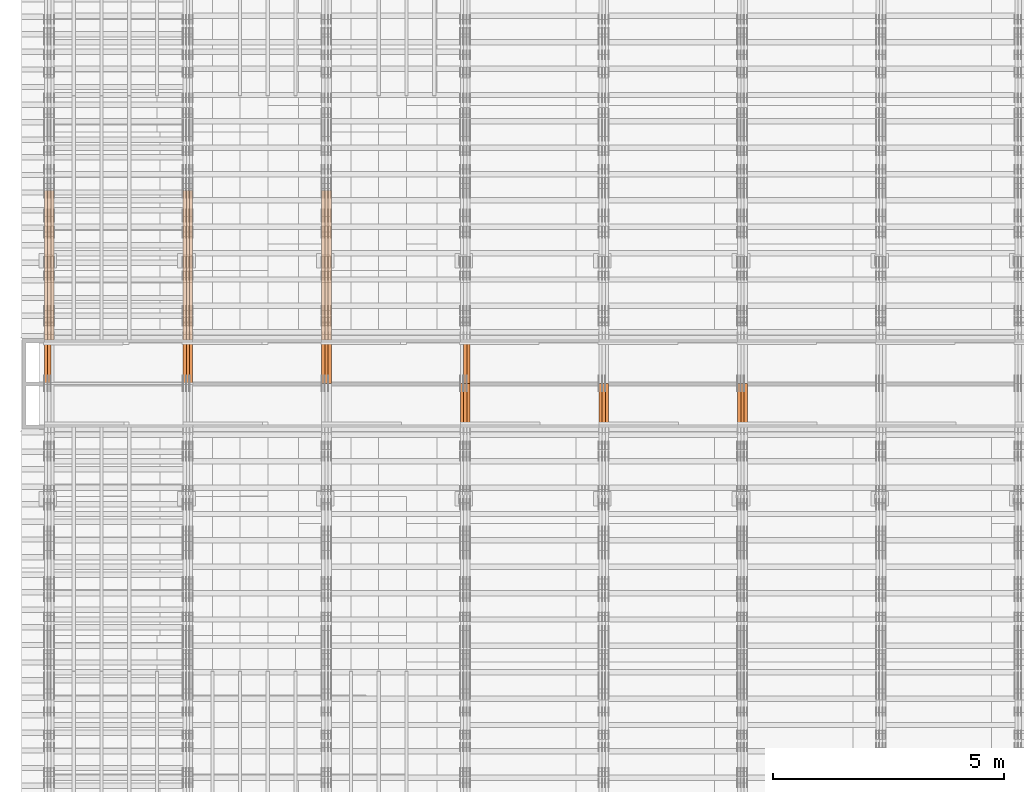
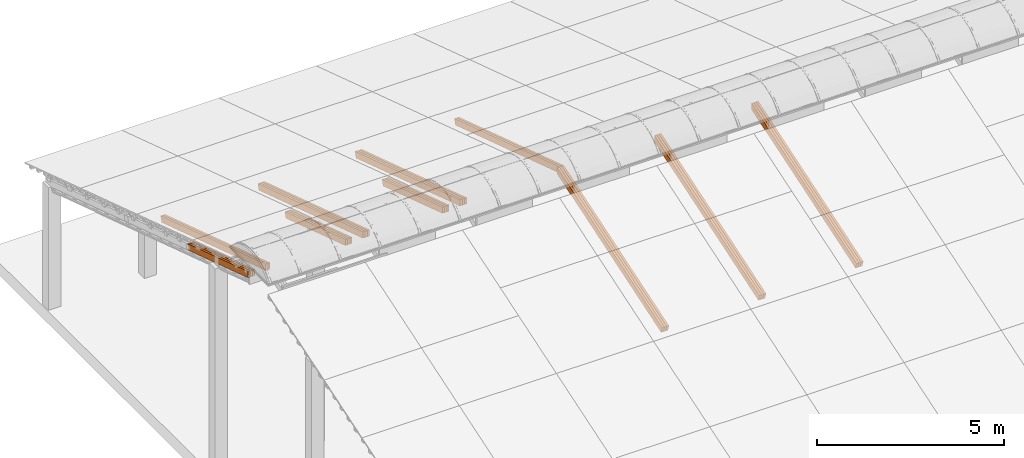
# One storey, part 14 of 385: 28 proxies.
"""IFC2X3 building model written with IfcOpenShell, lengths in millimetres."""

from ifc_helpers import new_model, entity, si_unit, converted_unit, derived_unit, direction, frame, origin, place, context, subcontext, project, spatial, polyline, outline, extrude, source, transform, mapped, material, type_object, type_shapes, element, save


model = new_model("IFC2X3")

# Units and contexts
model_context = context("Model", 3, precision=0.01, world=origin(), true_north=direction((6.12303176911189e-17, 1.0)))
body_context = subcontext(model_context, "Body", "Model", "MODEL_VIEW")
ifc_project = project(units=[si_unit("LENGTHUNIT", "METRE", prefix="MILLI"), si_unit("AREAUNIT", "SQUARE_METRE"), si_unit("VOLUMEUNIT", "CUBIC_METRE"), converted_unit("PLANEANGLEUNIT", "DEGREE", entity("IfcRatioMeasure", 0.0174532925199433), si_unit("PLANEANGLEUNIT", "RADIAN"), dimensions=[0, 0, 0, 0, 0, 0, 0]), si_unit("MASSUNIT", "GRAM", prefix="KILO"), derived_unit("MASSDENSITYUNIT", [(si_unit("MASSUNIT", "GRAM", prefix="KILO"), 1), (si_unit("LENGTHUNIT", "METRE"), -3)]), si_unit("TIMEUNIT", "SECOND"), si_unit("FREQUENCYUNIT", "HERTZ"), si_unit("THERMODYNAMICTEMPERATUREUNIT", "DEGREE_CELSIUS"), derived_unit("THERMALTRANSMITTANCEUNIT", [(si_unit("MASSUNIT", "GRAM", prefix="KILO"), 1), (si_unit("THERMODYNAMICTEMPERATUREUNIT", "KELVIN"), -1), (si_unit("TIMEUNIT", "SECOND"), -3)]), derived_unit("VOLUMETRICFLOWRATEUNIT", [(si_unit("LENGTHUNIT", "METRE"), 3), (si_unit("TIMEUNIT", "SECOND"), -1)]), si_unit("ELECTRICCURRENTUNIT", "AMPERE"), si_unit("ELECTRICVOLTAGEUNIT", "VOLT"), si_unit("POWERUNIT", "WATT"), si_unit("FORCEUNIT", "NEWTON", prefix="KILO"), si_unit("ILLUMINANCEUNIT", "LUX"), si_unit("LUMINOUSFLUXUNIT", "LUMEN"), si_unit("LUMINOUSINTENSITYUNIT", "CANDELA"), derived_unit("USERDEFINED", [(si_unit("MASSUNIT", "GRAM", prefix="KILO"), -1), (si_unit("LENGTHUNIT", "METRE"), -2), (si_unit("TIMEUNIT", "SECOND"), 3), (si_unit("LUMINOUSFLUXUNIT", "LUMEN"), 1)]), derived_unit("LINEARVELOCITYUNIT", [(si_unit("LENGTHUNIT", "METRE"), 1), (si_unit("TIMEUNIT", "SECOND"), -1)]), si_unit("PRESSUREUNIT", "PASCAL"), derived_unit("USERDEFINED", [(si_unit("LENGTHUNIT", "METRE"), -2), (si_unit("MASSUNIT", "GRAM", prefix="KILO"), 1), (si_unit("TIMEUNIT", "SECOND"), -2)])], contexts=[model_context])

# Site, building, storey
site_placement = place(None, origin())
site = spatial("IfcSite", under=ifc_project, at=site_placement, CompositionType="ELEMENT")
building_placement = place(site_placement, origin())
building = spatial("IfcBuilding", under=site, at=building_placement, CompositionType="ELEMENT")
storey_placement = place(building_placement, origin())
storey = spatial("IfcBuildingStorey", under=building, at=storey_placement, Name="Default", CompositionType="ELEMENT", Elevation=0.0)

# Proxies
ifc_material_1 = material(Name="IfcSurfaceStyle #179665")
building_element_proxy_type_1 = type_object("IfcBuildingElementProxyType", Name="T1-T1 179663", PredefinedType="NOTDEFINED", material=ifc_material_1)
shared_shape_1 = source(origin(), body_context, "Body", "SweptSolid", [
    extrude(outline(polyline([(-2938.84391703088, -97.499801613968), (2970.52383457984, -97.499801613968), (2907.16448685427, 97.499801613968), (-2938.84440440323, 97.499801613968), (-2938.84391703088, -97.499801613968)])), frame((2970.52383457984, 97.5000757893295, 0.0), z_axis=(0.0, 0.0, 1.0), x_axis=(-1.0, 0.0, 0.0)), (0.0, 0.0, 1.0), 69.9999999999996),
])
type_shapes(building_element_proxy_type_1, [shared_shape_1])
proxy_1_placement = place(building_placement, frame((15385.0, 14780.2584052475, 4242.0978974122), z_axis=(-1.0, 0.0, 0.0), x_axis=(0.0, -0.951056516295154, -0.309016994374948)))
element("IfcBuildingElementProxy", 1, at=proxy_1_placement, inside=storey, type_object=building_element_proxy_type_1, material=ifc_material_1, Name="T1-T1", context=body_context, shape_type="MappedRepresentation", body=[
    mapped(shared_shape_1, transform((0.0, 0.0, 0.0), scale=1.0)),
])
ifc_material_2 = material(Name="IfcSurfaceStyle #179608")
building_element_proxy_type_2 = type_object("IfcBuildingElementProxyType", Name="T1-T1 179606", PredefinedType="NOTDEFINED", material=ifc_material_2)
shared_shape_2 = source(origin(), body_context, "Body", "SweptSolid", [
    extrude(outline(polyline([(-2938.84391703088, -97.499801613968), (2970.52383457984, -97.499801613968), (2907.16448685427, 97.499801613968), (-2938.84440440323, 97.499801613968), (-2938.84391703088, -97.499801613968)])), frame((2970.52383457984, 97.5000757893295, 0.0), z_axis=(0.0, 0.0, 1.0), x_axis=(-1.0, 0.0, 0.0)), (0.0, 0.0, 1.0), 69.9999999999996),
])
type_shapes(building_element_proxy_type_2, [shared_shape_2])
proxy_2_placement = place(building_placement, frame((15315.0, 14780.2584052475, 4242.0978974122), z_axis=(-1.0, 0.0, 0.0), x_axis=(0.0, -0.951056516295154, -0.309016994374948)))
element("IfcBuildingElementProxy", 2, at=proxy_2_placement, inside=storey, type_object=building_element_proxy_type_2, material=ifc_material_2, Name="T1-T1", context=body_context, shape_type="MappedRepresentation", body=[
    mapped(shared_shape_2, transform((0.0, 0.0, 0.0), scale=1.0)),
])
ifc_material_3 = material(Name="IfcSurfaceStyle #179551")
building_element_proxy_type_3 = type_object("IfcBuildingElementProxyType", Name="T1-T1 179549", PredefinedType="NOTDEFINED", material=ifc_material_3)
shared_shape_3 = source(origin(), body_context, "Body", "SweptSolid", [
    extrude(outline(polyline([(-2938.84391703088, -97.499801613968), (2970.52383457984, -97.499801613968), (2907.16448685427, 97.499801613968), (-2938.84440440323, 97.499801613968), (-2938.84391703088, -97.499801613968)])), frame((2970.52383457984, 97.5000757893295, 0.0), z_axis=(0.0, 0.0, 1.0), x_axis=(-1.0, 0.0, 0.0)), (0.0, 0.0, 1.0), 69.9999999999996),
])
type_shapes(building_element_proxy_type_3, [shared_shape_3])
proxy_3_placement = place(building_placement, frame((15245.0, 14780.2584052475, 4242.0978974122), z_axis=(-1.0, 0.0, 0.0), x_axis=(0.0, -0.951056516295154, -0.309016994374948)))
element("IfcBuildingElementProxy", 3, at=proxy_3_placement, inside=storey, type_object=building_element_proxy_type_3, material=ifc_material_3, Name="T1-T1", context=body_context, shape_type="MappedRepresentation", body=[
    mapped(shared_shape_3, transform((0.0, 0.0, 0.0), scale=1.0)),
])
ifc_material_4 = material(Name="IfcSurfaceStyle #145233")
building_element_proxy_type_4 = type_object("IfcBuildingElementProxyType", Name="T1-T1 145231", PredefinedType="NOTDEFINED", material=ifc_material_4)
shared_shape_4 = source(origin(), body_context, "Body", "SweptSolid", [
    extrude(outline(polyline([(-2938.84391703088, -97.499801613968), (2970.52383457984, -97.499801613968), (2907.16448685427, 97.499801613968), (-2938.84440440323, 97.499801613968), (-2938.84391703088, -97.499801613968)])), frame((2970.52383457984, 97.5000757893295, 0.0), z_axis=(0.0, 0.0, 1.0), x_axis=(-1.0, 0.0, 0.0)), (0.0, 0.0, 1.0), 69.9999999999996),
])
type_shapes(building_element_proxy_type_4, [shared_shape_4])
proxy_4_placement = place(building_placement, frame((12385.0, 14780.2584052475, 4242.0978974122), z_axis=(-1.0, 0.0, 0.0), x_axis=(0.0, -0.951056516295154, -0.309016994374948)))
element("IfcBuildingElementProxy", 4, at=proxy_4_placement, inside=storey, type_object=building_element_proxy_type_4, material=ifc_material_4, Name="T1-T1", context=body_context, shape_type="MappedRepresentation", body=[
    mapped(shared_shape_4, transform((0.0, 0.0, 0.0), scale=1.0)),
])
ifc_material_5 = material(Name="IfcSurfaceStyle #145176")
building_element_proxy_type_5 = type_object("IfcBuildingElementProxyType", Name="T1-T1 145174", PredefinedType="NOTDEFINED", material=ifc_material_5)
shared_shape_5 = source(origin(), body_context, "Body", "SweptSolid", [
    extrude(outline(polyline([(-2938.84391703088, -97.499801613968), (2970.52383457984, -97.499801613968), (2907.16448685427, 97.499801613968), (-2938.84440440323, 97.499801613968), (-2938.84391703088, -97.499801613968)])), frame((2970.52383457984, 97.5000757893295, 0.0), z_axis=(0.0, 0.0, 1.0), x_axis=(-1.0, 0.0, 0.0)), (0.0, 0.0, 1.0), 69.9999999999996),
])
type_shapes(building_element_proxy_type_5, [shared_shape_5])
proxy_5_placement = place(building_placement, frame((12315.0, 14780.2584052475, 4242.0978974122), z_axis=(-1.0, 0.0, 0.0), x_axis=(0.0, -0.951056516295154, -0.309016994374948)))
element("IfcBuildingElementProxy", 5, at=proxy_5_placement, inside=storey, type_object=building_element_proxy_type_5, material=ifc_material_5, Name="T1-T1", context=body_context, shape_type="MappedRepresentation", body=[
    mapped(shared_shape_5, transform((0.0, 0.0, 0.0), scale=1.0)),
])
ifc_material_6 = material(Name="IfcSurfaceStyle #145119")
building_element_proxy_type_6 = type_object("IfcBuildingElementProxyType", Name="T1-T1 145117", PredefinedType="NOTDEFINED", material=ifc_material_6)
shared_shape_6 = source(origin(), body_context, "Body", "SweptSolid", [
    extrude(outline(polyline([(-2938.84391703088, -97.499801613968), (2970.52383457984, -97.499801613968), (2907.16448685427, 97.499801613968), (-2938.84440440323, 97.499801613968), (-2938.84391703088, -97.499801613968)])), frame((2970.52383457984, 97.5000757893295, 0.0), z_axis=(0.0, 0.0, 1.0), x_axis=(-1.0, 0.0, 0.0)), (0.0, 0.0, 1.0), 69.9999999999996),
])
type_shapes(building_element_proxy_type_6, [shared_shape_6])
proxy_6_placement = place(building_placement, frame((12245.0, 14780.2584052475, 4242.0978974122), z_axis=(-1.0, 0.0, 0.0), x_axis=(0.0, -0.951056516295154, -0.309016994374948)))
element("IfcBuildingElementProxy", 6, at=proxy_6_placement, inside=storey, type_object=building_element_proxy_type_6, material=ifc_material_6, Name="T1-T1", context=body_context, shape_type="MappedRepresentation", body=[
    mapped(shared_shape_6, transform((0.0, 0.0, 0.0), scale=1.0)),
])
ifc_material_7 = material(Name="IfcSurfaceStyle #111656")
building_element_proxy_type_7 = type_object("IfcBuildingElementProxyType", Name="T1-T1 111654", PredefinedType="NOTDEFINED", material=ifc_material_7)
shared_shape_7 = source(origin(), body_context, "Body", "SweptSolid", [
    extrude(outline(polyline([(-2970.52406677137, -97.5001477982598), (2938.84461360547, -97.5001477982598), (2938.8441722117, 97.5001477982599), (-2907.1647190458, 97.5001477982598), (-2970.52406677137, -97.5001477982598)])), frame((2938.84461360547, 97.5001477982598, 0.0), z_axis=(0.0, 0.0, 1.0), x_axis=(-1.0, 0.0, 0.0)), (0.0, 0.0, 1.0), 69.9999999999996),
])
type_shapes(building_element_proxy_type_7, [shared_shape_7])
proxy_7_placement = place(building_placement, frame((9385.0, 20279.8851854154, 2416.0025491487), z_axis=(-1.0, 0.0, 0.0), x_axis=(0.0, -0.951056516295154, 0.309016994374948)))
element("IfcBuildingElementProxy", 7, at=proxy_7_placement, inside=storey, type_object=building_element_proxy_type_7, material=ifc_material_7, Name="T1-T1", context=body_context, shape_type="MappedRepresentation", body=[
    mapped(shared_shape_7, transform((0.0, 0.0, 0.0), scale=1.0)),
])
ifc_material_8 = material(Name="IfcSurfaceStyle #111599")
building_element_proxy_type_8 = type_object("IfcBuildingElementProxyType", Name="T1-T1 111597", PredefinedType="NOTDEFINED", material=ifc_material_8)
shared_shape_8 = source(origin(), body_context, "Body", "SweptSolid", [
    extrude(outline(polyline([(-2970.52406677137, -97.5001477982598), (2938.84461360547, -97.5001477982598), (2938.8441722117, 97.5001477982599), (-2907.1647190458, 97.5001477982598), (-2970.52406677137, -97.5001477982598)])), frame((2938.84461360547, 97.5001477982598, 0.0), z_axis=(0.0, 0.0, 1.0), x_axis=(-1.0, 0.0, 0.0)), (0.0, 0.0, 1.0), 69.9999999999996),
])
type_shapes(building_element_proxy_type_8, [shared_shape_8])
proxy_8_placement = place(building_placement, frame((9315.0, 20279.8851854154, 2416.0025491487), z_axis=(-1.0, 0.0, 0.0), x_axis=(0.0, -0.951056516295154, 0.309016994374948)))
element("IfcBuildingElementProxy", 8, at=proxy_8_placement, inside=storey, type_object=building_element_proxy_type_8, material=ifc_material_8, Name="T1-T1", context=body_context, shape_type="MappedRepresentation", body=[
    mapped(shared_shape_8, transform((0.0, 0.0, 0.0), scale=1.0)),
])
ifc_material_9 = material(Name="IfcSurfaceStyle #110801")
building_element_proxy_type_9 = type_object("IfcBuildingElementProxyType", Name="T1-T1 110799", PredefinedType="NOTDEFINED", material=ifc_material_9)
shared_shape_9 = source(origin(), body_context, "Body", "SweptSolid", [
    extrude(outline(polyline([(-2938.84391703088, -97.499801613968), (2970.52383457984, -97.499801613968), (2907.16448685427, 97.499801613968), (-2938.84440440323, 97.499801613968), (-2938.84391703088, -97.499801613968)])), frame((2970.52383457984, 97.5000757893295, 0.0), z_axis=(0.0, 0.0, 1.0), x_axis=(-1.0, 0.0, 0.0)), (0.0, 0.0, 1.0), 69.9999999999996),
])
type_shapes(building_element_proxy_type_9, [shared_shape_9])
proxy_9_placement = place(building_placement, frame((9385.0, 14780.2584052475, 4242.0978974122), z_axis=(-1.0, 0.0, 0.0), x_axis=(0.0, -0.951056516295154, -0.309016994374948)))
element("IfcBuildingElementProxy", 9, at=proxy_9_placement, inside=storey, type_object=building_element_proxy_type_9, material=ifc_material_9, Name="T1-T1", context=body_context, shape_type="MappedRepresentation", body=[
    mapped(shared_shape_9, transform((0.0, 0.0, 0.0), scale=1.0)),
])
ifc_material_10 = material(Name="IfcSurfaceStyle #110744")
building_element_proxy_type_10 = type_object("IfcBuildingElementProxyType", Name="T1-T1 110742", PredefinedType="NOTDEFINED", material=ifc_material_10)
shared_shape_10 = source(origin(), body_context, "Body", "SweptSolid", [
    extrude(outline(polyline([(-2938.84391703088, -97.499801613968), (2970.52383457984, -97.499801613968), (2907.16448685427, 97.499801613968), (-2938.84440440323, 97.499801613968), (-2938.84391703088, -97.499801613968)])), frame((2970.52383457984, 97.5000757893295, 0.0), z_axis=(0.0, 0.0, 1.0), x_axis=(-1.0, 0.0, 0.0)), (0.0, 0.0, 1.0), 69.9999999999996),
])
type_shapes(building_element_proxy_type_10, [shared_shape_10])
proxy_10_placement = place(building_placement, frame((9315.0, 14780.2584052475, 4242.0978974122), z_axis=(-1.0, 0.0, 0.0), x_axis=(0.0, -0.951056516295154, -0.309016994374948)))
element("IfcBuildingElementProxy", 10, at=proxy_10_placement, inside=storey, type_object=building_element_proxy_type_10, material=ifc_material_10, Name="T1-T1", context=body_context, shape_type="MappedRepresentation", body=[
    mapped(shared_shape_10, transform((0.0, 0.0, 0.0), scale=1.0)),
])
ifc_material_11 = material(Name="IfcSurfaceStyle #110687")
building_element_proxy_type_11 = type_object("IfcBuildingElementProxyType", Name="T1-T1 110685", PredefinedType="NOTDEFINED", material=ifc_material_11)
shared_shape_11 = source(origin(), body_context, "Body", "SweptSolid", [
    extrude(outline(polyline([(-2938.84391703088, -97.499801613968), (2970.52383457984, -97.499801613968), (2907.16448685427, 97.499801613968), (-2938.84440440323, 97.499801613968), (-2938.84391703088, -97.499801613968)])), frame((2970.52383457984, 97.5000757893295, 0.0), z_axis=(0.0, 0.0, 1.0), x_axis=(-1.0, 0.0, 0.0)), (0.0, 0.0, 1.0), 69.9999999999996),
])
type_shapes(building_element_proxy_type_11, [shared_shape_11])
proxy_11_placement = place(building_placement, frame((9245.0, 14780.2584052475, 4242.0978974122), z_axis=(-1.0, 0.0, 0.0), x_axis=(0.0, -0.951056516295154, -0.309016994374948)))
element("IfcBuildingElementProxy", 11, at=proxy_11_placement, inside=storey, type_object=building_element_proxy_type_11, material=ifc_material_11, Name="T1-T1", context=body_context, shape_type="MappedRepresentation", body=[
    mapped(shared_shape_11, transform((0.0, 0.0, 0.0), scale=1.0)),
])
ifc_material_12 = material(Name="IfcSurfaceStyle #77224")
building_element_proxy_type_12 = type_object("IfcBuildingElementProxyType", Name="T1-T1 77222", PredefinedType="NOTDEFINED", material=ifc_material_12)
shared_shape_12 = source(origin(), body_context, "Body", "SweptSolid", [
    extrude(outline(polyline([(-2970.52406677137, -97.5001477982598), (2938.84461360547, -97.5001477982598), (2938.8441722117, 97.5001477982599), (-2907.1647190458, 97.5001477982598), (-2970.52406677137, -97.5001477982598)])), frame((2938.84461360547, 97.5001477982598, 0.0), z_axis=(0.0, 0.0, 1.0), x_axis=(-1.0, 0.0, 0.0)), (0.0, 0.0, 1.0), 69.9999999999996),
])
type_shapes(building_element_proxy_type_12, [shared_shape_12])
proxy_12_placement = place(building_placement, frame((6385.0, 20279.8851854154, 2416.0025491487), z_axis=(-1.0, 0.0, 0.0), x_axis=(0.0, -0.951056516295154, 0.309016994374948)))
element("IfcBuildingElementProxy", 12, at=proxy_12_placement, inside=storey, type_object=building_element_proxy_type_12, material=ifc_material_12, Name="T1-T1", context=body_context, shape_type="MappedRepresentation", body=[
    mapped(shared_shape_12, transform((0.0, 0.0, 0.0), scale=1.0)),
])
ifc_material_13 = material(Name="IfcSurfaceStyle #77167")
building_element_proxy_type_13 = type_object("IfcBuildingElementProxyType", Name="T1-T1 77165", PredefinedType="NOTDEFINED", material=ifc_material_13)
shared_shape_13 = source(origin(), body_context, "Body", "SweptSolid", [
    extrude(outline(polyline([(-2970.52406677137, -97.5001477982598), (2938.84461360547, -97.5001477982598), (2938.8441722117, 97.5001477982599), (-2907.1647190458, 97.5001477982598), (-2970.52406677137, -97.5001477982598)])), frame((2938.84461360547, 97.5001477982598, 0.0), z_axis=(0.0, 0.0, 1.0), x_axis=(-1.0, 0.0, 0.0)), (0.0, 0.0, 1.0), 69.9999999999996),
])
type_shapes(building_element_proxy_type_13, [shared_shape_13])
proxy_13_placement = place(building_placement, frame((6315.0, 20279.8851854154, 2416.0025491487), z_axis=(-1.0, 0.0, 0.0), x_axis=(0.0, -0.951056516295154, 0.309016994374948)))
element("IfcBuildingElementProxy", 13, at=proxy_13_placement, inside=storey, type_object=building_element_proxy_type_13, material=ifc_material_13, Name="T1-T1", context=body_context, shape_type="MappedRepresentation", body=[
    mapped(shared_shape_13, transform((0.0, 0.0, 0.0), scale=1.0)),
])
ifc_material_14 = material(Name="IfcSurfaceStyle #77110")
building_element_proxy_type_14 = type_object("IfcBuildingElementProxyType", Name="T1-T1 77108", PredefinedType="NOTDEFINED", material=ifc_material_14)
shared_shape_14 = source(origin(), body_context, "Body", "SweptSolid", [
    extrude(outline(polyline([(-2970.52406677137, -97.5001477982598), (2938.84461360547, -97.5001477982598), (2938.8441722117, 97.5001477982599), (-2907.1647190458, 97.5001477982598), (-2970.52406677137, -97.5001477982598)])), frame((2938.84461360547, 97.5001477982598, 0.0), z_axis=(0.0, 0.0, 1.0), x_axis=(-1.0, 0.0, 0.0)), (0.0, 0.0, 1.0), 69.9999999999996),
])
type_shapes(building_element_proxy_type_14, [shared_shape_14])
proxy_14_placement = place(building_placement, frame((6245.0, 20279.8851854154, 2416.0025491487), z_axis=(-1.0, 0.0, 0.0), x_axis=(0.0, -0.951056516295154, 0.309016994374948)))
element("IfcBuildingElementProxy", 14, at=proxy_14_placement, inside=storey, type_object=building_element_proxy_type_14, material=ifc_material_14, Name="T1-T1", context=body_context, shape_type="MappedRepresentation", body=[
    mapped(shared_shape_14, transform((0.0, 0.0, 0.0), scale=1.0)),
])
ifc_material_15 = material(Name="IfcSurfaceStyle #75829")
building_element_proxy_type_15 = type_object("IfcBuildingElementProxyType", Name="T1-B3 75827", PredefinedType="NOTDEFINED", material=ifc_material_15)
shared_shape_15 = source(origin(), body_context, "Body", "SweptSolid", [
    extrude(outline(polyline([(-1715.8757175801, -97.4999653079672), (1684.19580003112, -97.4999653079672), (1684.19628740349, 97.4999653079672), (-1652.51636985451, 97.4999653079672), (-1715.8757175801, -97.4999653079672)])), frame((1684.19628740349, 97.5000561131842, 0.0), z_axis=(0.0, 0.0, 1.0), x_axis=(-1.0, 0.0, 0.0)), (0.0, 0.0, 1.0), 69.9999999999998),
])
type_shapes(building_element_proxy_type_15, [shared_shape_15])
proxy_15_placement = place(building_placement, frame((6385.0, 18833.4023156897, 2380.55582184223), z_axis=(-1.0, 0.0, 0.0), x_axis=(0.0, -0.951056516295124, 0.309016994375039)))
element("IfcBuildingElementProxy", 15, at=proxy_15_placement, inside=storey, type_object=building_element_proxy_type_15, material=ifc_material_15, Name="T1-B3", context=body_context, shape_type="MappedRepresentation", body=[
    mapped(shared_shape_15, transform((0.0, 0.0, 0.0), scale=1.0)),
])
ifc_material_16 = material(Name="IfcSurfaceStyle #75772")
building_element_proxy_type_16 = type_object("IfcBuildingElementProxyType", Name="T1-B3 75770", PredefinedType="NOTDEFINED", material=ifc_material_16)
shared_shape_16 = source(origin(), body_context, "Body", "SweptSolid", [
    extrude(outline(polyline([(-1715.8757175801, -97.4999653079672), (1684.19580003112, -97.4999653079672), (1684.19628740349, 97.4999653079672), (-1652.51636985451, 97.4999653079672), (-1715.8757175801, -97.4999653079672)])), frame((1684.19628740349, 97.5000561131842, 0.0), z_axis=(0.0, 0.0, 1.0), x_axis=(-1.0, 0.0, 0.0)), (0.0, 0.0, 1.0), 69.9999999999998),
])
type_shapes(building_element_proxy_type_16, [shared_shape_16])
proxy_16_placement = place(building_placement, frame((6315.0, 18833.4023156897, 2380.55582184223), z_axis=(-1.0, 0.0, 0.0), x_axis=(0.0, -0.951056516295124, 0.309016994375039)))
element("IfcBuildingElementProxy", 16, at=proxy_16_placement, inside=storey, type_object=building_element_proxy_type_16, material=ifc_material_16, Name="T1-B3", context=body_context, shape_type="MappedRepresentation", body=[
    mapped(shared_shape_16, transform((0.0, 0.0, 0.0), scale=1.0)),
])
ifc_material_17 = material(Name="IfcSurfaceStyle #75715")
building_element_proxy_type_17 = type_object("IfcBuildingElementProxyType", Name="T1-B3 75713", PredefinedType="NOTDEFINED", material=ifc_material_17)
shared_shape_17 = source(origin(), body_context, "Body", "SweptSolid", [
    extrude(outline(polyline([(-1715.8757175801, -97.4999653079672), (1684.19580003112, -97.4999653079672), (1684.19628740349, 97.4999653079672), (-1652.51636985451, 97.4999653079672), (-1715.8757175801, -97.4999653079672)])), frame((1684.19628740349, 97.5000561131842, 0.0), z_axis=(0.0, 0.0, 1.0), x_axis=(-1.0, 0.0, 0.0)), (0.0, 0.0, 1.0), 69.9999999999998),
])
type_shapes(building_element_proxy_type_17, [shared_shape_17])
proxy_17_placement = place(building_placement, frame((6245.0, 18833.4023156897, 2380.55582184223), z_axis=(-1.0, 0.0, 0.0), x_axis=(0.0, -0.951056516295124, 0.309016994375039)))
element("IfcBuildingElementProxy", 17, at=proxy_17_placement, inside=storey, type_object=building_element_proxy_type_17, material=ifc_material_17, Name="T1-B3", context=body_context, shape_type="MappedRepresentation", body=[
    mapped(shared_shape_17, transform((0.0, 0.0, 0.0), scale=1.0)),
])
ifc_material_18 = material(Name="IfcSurfaceStyle #42792")
building_element_proxy_type_18 = type_object("IfcBuildingElementProxyType", Name="T1-T1 42790", PredefinedType="NOTDEFINED", material=ifc_material_18)
shared_shape_18 = source(origin(), body_context, "Body", "SweptSolid", [
    extrude(outline(polyline([(-2970.52406677137, -97.5001477982598), (2938.84461360547, -97.5001477982598), (2938.8441722117, 97.5001477982599), (-2907.1647190458, 97.5001477982598), (-2970.52406677137, -97.5001477982598)])), frame((2938.84461360547, 97.5001477982598, 0.0), z_axis=(0.0, 0.0, 1.0), x_axis=(-1.0, 0.0, 0.0)), (0.0, 0.0, 1.0), 69.9999999999996),
])
type_shapes(building_element_proxy_type_18, [shared_shape_18])
proxy_18_placement = place(building_placement, frame((3385.0, 20279.8851854154, 2416.0025491487), z_axis=(-1.0, 0.0, 0.0), x_axis=(0.0, -0.951056516295154, 0.309016994374948)))
element("IfcBuildingElementProxy", 18, at=proxy_18_placement, inside=storey, type_object=building_element_proxy_type_18, material=ifc_material_18, Name="T1-T1", context=body_context, shape_type="MappedRepresentation", body=[
    mapped(shared_shape_18, transform((0.0, 0.0, 0.0), scale=1.0)),
])
ifc_material_19 = material(Name="IfcSurfaceStyle #42735")
building_element_proxy_type_19 = type_object("IfcBuildingElementProxyType", Name="T1-T1 42733", PredefinedType="NOTDEFINED", material=ifc_material_19)
shared_shape_19 = source(origin(), body_context, "Body", "SweptSolid", [
    extrude(outline(polyline([(-2970.52406677137, -97.5001477982598), (2938.84461360547, -97.5001477982598), (2938.8441722117, 97.5001477982599), (-2907.1647190458, 97.5001477982598), (-2970.52406677137, -97.5001477982598)])), frame((2938.84461360547, 97.5001477982598, 0.0), z_axis=(0.0, 0.0, 1.0), x_axis=(-1.0, 0.0, 0.0)), (0.0, 0.0, 1.0), 69.9999999999996),
])
type_shapes(building_element_proxy_type_19, [shared_shape_19])
proxy_19_placement = place(building_placement, frame((3315.0, 20279.8851854154, 2416.0025491487), z_axis=(-1.0, 0.0, 0.0), x_axis=(0.0, -0.951056516295154, 0.309016994374948)))
element("IfcBuildingElementProxy", 19, at=proxy_19_placement, inside=storey, type_object=building_element_proxy_type_19, material=ifc_material_19, Name="T1-T1", context=body_context, shape_type="MappedRepresentation", body=[
    mapped(shared_shape_19, transform((0.0, 0.0, 0.0), scale=1.0)),
])
ifc_material_20 = material(Name="IfcSurfaceStyle #42678")
building_element_proxy_type_20 = type_object("IfcBuildingElementProxyType", Name="T1-T1 42676", PredefinedType="NOTDEFINED", material=ifc_material_20)
shared_shape_20 = source(origin(), body_context, "Body", "SweptSolid", [
    extrude(outline(polyline([(-2970.52406677137, -97.5001477982598), (2938.84461360547, -97.5001477982598), (2938.8441722117, 97.5001477982599), (-2907.1647190458, 97.5001477982598), (-2970.52406677137, -97.5001477982598)])), frame((2938.84461360547, 97.5001477982598, 0.0), z_axis=(0.0, 0.0, 1.0), x_axis=(-1.0, 0.0, 0.0)), (0.0, 0.0, 1.0), 69.9999999999996),
])
type_shapes(building_element_proxy_type_20, [shared_shape_20])
proxy_20_placement = place(building_placement, frame((3245.0, 20279.8851854154, 2416.0025491487), z_axis=(-1.0, 0.0, 0.0), x_axis=(0.0, -0.951056516295154, 0.309016994374948)))
element("IfcBuildingElementProxy", 20, at=proxy_20_placement, inside=storey, type_object=building_element_proxy_type_20, material=ifc_material_20, Name="T1-T1", context=body_context, shape_type="MappedRepresentation", body=[
    mapped(shared_shape_20, transform((0.0, 0.0, 0.0), scale=1.0)),
])
ifc_material_21 = material(Name="IfcSurfaceStyle #41397")
building_element_proxy_type_21 = type_object("IfcBuildingElementProxyType", Name="T1-B3 41395", PredefinedType="NOTDEFINED", material=ifc_material_21)
shared_shape_21 = source(origin(), body_context, "Body", "SweptSolid", [
    extrude(outline(polyline([(-1715.8757175801, -97.4999653079672), (1684.19580003112, -97.4999653079672), (1684.19628740349, 97.4999653079672), (-1652.51636985451, 97.4999653079672), (-1715.8757175801, -97.4999653079672)])), frame((1684.19628740349, 97.5000561131842, 0.0), z_axis=(0.0, 0.0, 1.0), x_axis=(-1.0, 0.0, 0.0)), (0.0, 0.0, 1.0), 69.9999999999998),
])
type_shapes(building_element_proxy_type_21, [shared_shape_21])
proxy_21_placement = place(building_placement, frame((3385.0, 18833.4023156896, 2380.55582184223), z_axis=(-1.0, 0.0, 0.0), x_axis=(0.0, -0.951056516295124, 0.309016994375039)))
element("IfcBuildingElementProxy", 21, at=proxy_21_placement, inside=storey, type_object=building_element_proxy_type_21, material=ifc_material_21, Name="T1-B3", context=body_context, shape_type="MappedRepresentation", body=[
    mapped(shared_shape_21, transform((0.0, 0.0, 0.0), scale=1.0)),
])
ifc_material_22 = material(Name="IfcSurfaceStyle #41340")
building_element_proxy_type_22 = type_object("IfcBuildingElementProxyType", Name="T1-B3 41338", PredefinedType="NOTDEFINED", material=ifc_material_22)
shared_shape_22 = source(origin(), body_context, "Body", "SweptSolid", [
    extrude(outline(polyline([(-1715.8757175801, -97.4999653079672), (1684.19580003112, -97.4999653079672), (1684.19628740349, 97.4999653079672), (-1652.51636985451, 97.4999653079672), (-1715.8757175801, -97.4999653079672)])), frame((1684.19628740349, 97.5000561131842, 0.0), z_axis=(0.0, 0.0, 1.0), x_axis=(-1.0, 0.0, 0.0)), (0.0, 0.0, 1.0), 69.9999999999998),
])
type_shapes(building_element_proxy_type_22, [shared_shape_22])
proxy_22_placement = place(building_placement, frame((3315.0, 18833.4023156896, 2380.55582184223), z_axis=(-1.0, 0.0, 0.0), x_axis=(0.0, -0.951056516295124, 0.309016994375039)))
element("IfcBuildingElementProxy", 22, at=proxy_22_placement, inside=storey, type_object=building_element_proxy_type_22, material=ifc_material_22, Name="T1-B3", context=body_context, shape_type="MappedRepresentation", body=[
    mapped(shared_shape_22, transform((0.0, 0.0, 0.0), scale=1.0)),
])
ifc_material_23 = material(Name="IfcSurfaceStyle #41283")
building_element_proxy_type_23 = type_object("IfcBuildingElementProxyType", Name="T1-B3 41281", PredefinedType="NOTDEFINED", material=ifc_material_23)
shared_shape_23 = source(origin(), body_context, "Body", "SweptSolid", [
    extrude(outline(polyline([(-1715.8757175801, -97.4999653079672), (1684.19580003112, -97.4999653079672), (1684.19628740349, 97.4999653079672), (-1652.51636985451, 97.4999653079672), (-1715.8757175801, -97.4999653079672)])), frame((1684.19628740349, 97.5000561131842, 0.0), z_axis=(0.0, 0.0, 1.0), x_axis=(-1.0, 0.0, 0.0)), (0.0, 0.0, 1.0), 69.9999999999998),
])
type_shapes(building_element_proxy_type_23, [shared_shape_23])
proxy_23_placement = place(building_placement, frame((3245.0, 18833.4023156896, 2380.55582184223), z_axis=(-1.0, 0.0, 0.0), x_axis=(0.0, -0.951056516295124, 0.309016994375039)))
element("IfcBuildingElementProxy", 23, at=proxy_23_placement, inside=storey, type_object=building_element_proxy_type_23, material=ifc_material_23, Name="T1-B3", context=body_context, shape_type="MappedRepresentation", body=[
    mapped(shared_shape_23, transform((0.0, 0.0, 0.0), scale=1.0)),
])
ifc_material_24 = material(Name="IfcSurfaceStyle #8303")
building_element_proxy_type_24 = type_object("IfcBuildingElementProxyType", Name="T1-T1 8301", PredefinedType="NOTDEFINED", material=ifc_material_24)
shared_shape_24 = source(origin(), body_context, "Body", "SweptSolid", [
    extrude(outline(polyline([(-2970.52406677137, -97.5001477982598), (2938.84461360547, -97.5001477982598), (2938.8441722117, 97.5001477982599), (-2907.1647190458, 97.5001477982598), (-2970.52406677137, -97.5001477982598)])), frame((2938.84461360547, 97.5001477982598, 0.0), z_axis=(0.0, 0.0, 1.0), x_axis=(-1.0, 0.0, 0.0)), (0.0, 0.0, 1.0), 69.9999999999996),
])
type_shapes(building_element_proxy_type_24, [shared_shape_24])
proxy_24_placement = place(building_placement, frame((315.0, 20279.8851854154, 2416.0025491487), z_axis=(-1.0, 0.0, 0.0), x_axis=(0.0, -0.951056516295154, 0.309016994374948)))
element("IfcBuildingElementProxy", 24, at=proxy_24_placement, inside=storey, type_object=building_element_proxy_type_24, material=ifc_material_24, Name="T1-T1", context=body_context, shape_type="MappedRepresentation", body=[
    mapped(shared_shape_24, transform((0.0, 0.0, 0.0), scale=1.0)),
])
ifc_material_25 = material(Name="IfcSurfaceStyle #8246")
building_element_proxy_type_25 = type_object("IfcBuildingElementProxyType", Name="T1-T1 8244", PredefinedType="NOTDEFINED", material=ifc_material_25)
shared_shape_25 = source(origin(), body_context, "Body", "SweptSolid", [
    extrude(outline(polyline([(-2970.52406677137, -97.5001477982598), (2938.84461360547, -97.5001477982598), (2938.8441722117, 97.5001477982599), (-2907.1647190458, 97.5001477982598), (-2970.52406677137, -97.5001477982598)])), frame((2938.84461360547, 97.5001477982598, 0.0), z_axis=(0.0, 0.0, 1.0), x_axis=(-1.0, 0.0, 0.0)), (0.0, 0.0, 1.0), 69.9999999999996),
])
type_shapes(building_element_proxy_type_25, [shared_shape_25])
proxy_25_placement = place(building_placement, frame((245.0, 20279.8851854154, 2416.0025491487), z_axis=(-1.0, 0.0, 0.0), x_axis=(0.0, -0.951056516295154, 0.309016994374948)))
element("IfcBuildingElementProxy", 25, at=proxy_25_placement, inside=storey, type_object=building_element_proxy_type_25, material=ifc_material_25, Name="T1-T1", context=body_context, shape_type="MappedRepresentation", body=[
    mapped(shared_shape_25, transform((0.0, 0.0, 0.0), scale=1.0)),
])
ifc_material_26 = material(Name="IfcSurfaceStyle #6965")
building_element_proxy_type_26 = type_object("IfcBuildingElementProxyType", Name="T1-B3 6963", PredefinedType="NOTDEFINED", material=ifc_material_26)
shared_shape_26 = source(origin(), body_context, "Body", "SweptSolid", [
    extrude(outline(polyline([(-1715.8757175801, -97.4999653079672), (1684.19580003112, -97.4999653079672), (1684.19628740349, 97.4999653079672), (-1652.51636985451, 97.4999653079672), (-1715.8757175801, -97.4999653079672)])), frame((1684.19628740349, 97.5000561131842, 0.0), z_axis=(0.0, 0.0, 1.0), x_axis=(-1.0, 0.0, 0.0)), (0.0, 0.0, 1.0), 69.9999999999998),
])
type_shapes(building_element_proxy_type_26, [shared_shape_26])
proxy_26_placement = place(building_placement, frame((385.0, 18833.4023156896, 2380.55582184223), z_axis=(-1.0, 0.0, 0.0), x_axis=(0.0, -0.951056516295124, 0.309016994375039)))
element("IfcBuildingElementProxy", 26, at=proxy_26_placement, inside=storey, type_object=building_element_proxy_type_26, material=ifc_material_26, Name="T1-B3", context=body_context, shape_type="MappedRepresentation", body=[
    mapped(shared_shape_26, transform((0.0, 0.0, 0.0), scale=1.0)),
])
ifc_material_27 = material(Name="IfcSurfaceStyle #6908")
building_element_proxy_type_27 = type_object("IfcBuildingElementProxyType", Name="T1-B3 6906", PredefinedType="NOTDEFINED", material=ifc_material_27)
shared_shape_27 = source(origin(), body_context, "Body", "SweptSolid", [
    extrude(outline(polyline([(-1715.8757175801, -97.4999653079672), (1684.19580003112, -97.4999653079672), (1684.19628740349, 97.4999653079672), (-1652.51636985451, 97.4999653079672), (-1715.8757175801, -97.4999653079672)])), frame((1684.19628740349, 97.5000561131842, 0.0), z_axis=(0.0, 0.0, 1.0), x_axis=(-1.0, 0.0, 0.0)), (0.0, 0.0, 1.0), 69.9999999999998),
])
type_shapes(building_element_proxy_type_27, [shared_shape_27])
proxy_27_placement = place(building_placement, frame((315.0, 18833.4023156896, 2380.55582184223), z_axis=(-1.0, 0.0, 0.0), x_axis=(0.0, -0.951056516295124, 0.309016994375039)))
element("IfcBuildingElementProxy", 27, at=proxy_27_placement, inside=storey, type_object=building_element_proxy_type_27, material=ifc_material_27, Name="T1-B3", context=body_context, shape_type="MappedRepresentation", body=[
    mapped(shared_shape_27, transform((0.0, 0.0, 0.0), scale=1.0)),
])
ifc_material_28 = material(Name="IfcSurfaceStyle #6851")
building_element_proxy_type_28 = type_object("IfcBuildingElementProxyType", Name="T1-B3 6849", PredefinedType="NOTDEFINED", material=ifc_material_28)
shared_shape_28 = source(origin(), body_context, "Body", "SweptSolid", [
    extrude(outline(polyline([(-1715.8757175801, -97.4999653079672), (1684.19580003112, -97.4999653079672), (1684.19628740349, 97.4999653079672), (-1652.51636985451, 97.4999653079672), (-1715.8757175801, -97.4999653079672)])), frame((1684.19628740349, 97.5000561131842, 0.0), z_axis=(0.0, 0.0, 1.0), x_axis=(-1.0, 0.0, 0.0)), (0.0, 0.0, 1.0), 69.9999999999998),
])
type_shapes(building_element_proxy_type_28, [shared_shape_28])
proxy_28_placement = place(building_placement, frame((245.0, 18833.4023156896, 2380.55582184223), z_axis=(-1.0, 0.0, 0.0), x_axis=(0.0, -0.951056516295124, 0.309016994375039)))
element("IfcBuildingElementProxy", 28, at=proxy_28_placement, inside=storey, type_object=building_element_proxy_type_28, material=ifc_material_28, Name="T1-B3", context=body_context, shape_type="MappedRepresentation", body=[
    mapped(shared_shape_28, transform((0.0, 0.0, 0.0), scale=1.0)),
])

save(model, "model.ifc")
